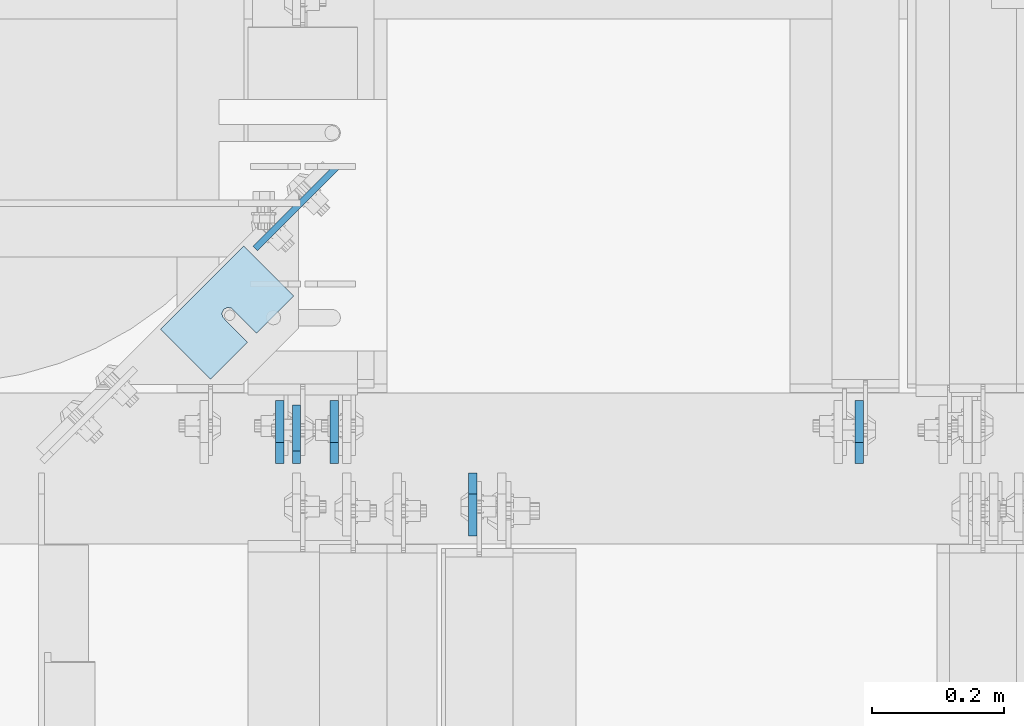
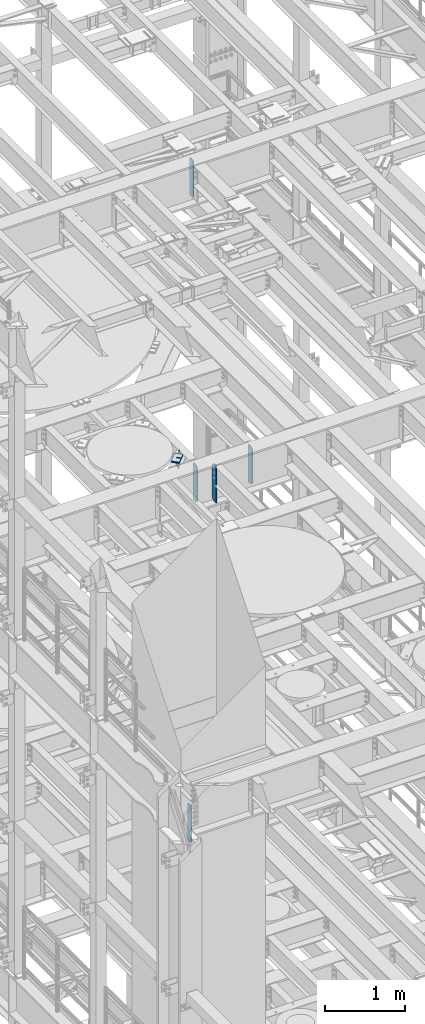
# One storey, part 1719 of 1876: 11 plates, 9 elements without a shape of their own.
"""IFC2X3 building model written with IfcOpenShell, lengths in millimetres."""

from ifc_helpers import new_model, si_unit, frame, origin_with_axes, place, context, subcontext, project, spatial, faceted_brep, material, type_object, element, aggregate, save


model = new_model("IFC2X3")

# Units and contexts
model_context = context("Model", 3, precision=1e-05, world=origin_with_axes())
body_context = subcontext(model_context, "Body", "Model", "MODEL_VIEW")
ifc_project = project(units=[si_unit("LENGTHUNIT", "METRE", prefix="MILLI"), si_unit("AREAUNIT", "SQUARE_METRE"), si_unit("VOLUMEUNIT", "CUBIC_METRE"), si_unit("MASSUNIT", "GRAM", prefix="KILO"), si_unit("TIMEUNIT", "SECOND"), si_unit("PLANEANGLEUNIT", "RADIAN"), si_unit("SOLIDANGLEUNIT", "STERADIAN"), si_unit("THERMODYNAMICTEMPERATUREUNIT", "DEGREE_CELSIUS"), si_unit("LUMINOUSINTENSITYUNIT", "LUMEN")], contexts=[model_context])

# Site, building, storey
site_placement = place(None, origin_with_axes())
site = spatial("IfcSite", under=ifc_project, at=site_placement, CompositionType="ELEMENT")
building_placement = place(site_placement, origin_with_axes())
building = spatial("IfcBuilding", under=site, at=building_placement, Name="Undefined", CompositionType="ELEMENT")
storey_placement = place(building_placement, origin_with_axes())
storey = spatial("IfcBuildingStorey", under=building, at=storey_placement, Name="Undefined", CompositionType="ELEMENT", Elevation=0.0)

# Assembly, plate
assembly_1_placement = place(storey_placement, origin_with_axes())
assembly_1 = element("IfcElementAssembly", 1, at=assembly_1_placement, inside=storey, Name="BEAM", AssemblyPlace="NOTDEFINED", PredefinedType="RIGID_FRAME")
ifc_material = material(Name="STEEL/A36")
plate_type_1 = type_object("IfcPlateType", PredefinedType="NOTDEFINED")
plate_1_placement = place(assembly_1_placement, frame((3784.40740341513, 8075.21362106345, 13275.2197438789), z_axis=(-0.707106781186547, -0.707106781186548, 0.0), x_axis=(0.0, 0.0, -1.0)))
plate_1 = element("IfcPlate", 2, at=plate_1_placement, type_object=plate_type_1, material=ifc_material, Name="PLATE", context=body_context, shape_type="Brep", body=[
    faceted_brep([(0.0, -4.76249999999982, 0.0), (0.0, -4.76250000000073, 173.535507202178), (0.0, 4.76250000000073, 173.535507202178), (0.0, 4.76249999999982, 0.0), (245.070301055908, -4.76250000000073, 1.81898940354586e-12), (245.070301055908, 4.76250000000255, 9.09494701772928e-13), (264.120300292969, -4.76249999999891, 19.0499992370651), (264.120300292969, 4.76250000000073, 19.0499992370651), (264.120300292969, -4.76250000000073, 63.5000000707769), (118.019743991599, -4.76250000000073, 173.535507202179), (118.019743991599, 4.76250000000073, 173.53550720218), (264.120300292969, 4.76250000000073, 63.5000000707773)], [[[0, 1, 2, 3]], [[4, 0, 3, 5]], [[6, 4, 5, 7]], [[1, 0, 4, 6, 8, 9]], [[2, 1, 9, 10]], [[7, 5, 3, 2, 10, 11]], [[6, 7, 11, 8]], [[10, 9, 8, 11]]]),
])
aggregate(assembly_1, [plate_1])

assembly_2_placement = place(storey_placement, origin_with_axes())
assembly_2 = element("IfcElementAssembly", 3, at=assembly_2_placement, inside=storey, Name="BEAM", AssemblyPlace="NOTDEFINED", PredefinedType="RIGID_FRAME")
plate_type_2 = type_object("IfcPlateType", PredefinedType="NOTDEFINED")
plate_2_placement = place(assembly_2_placement, frame((3724.27530593044, 7627.14375, 17387.8875), z_axis=(0.0, 0.0, 1.0), x_axis=(0.0, 1.0, 0.0)))
plate_2 = element("IfcPlate", 4, at=plate_2_placement, type_object=plate_type_2, material=ifc_material, Name="PLATE", context=body_context, shape_type="Brep", body=[
    faceted_brep([(0.0, -6.35000000000196, 19.0499992370605), (0.0, -6.34999999999991, 550.862476348877), (0.0, 6.34999999999991, 550.862476348877), (0.0, 6.35000000000105, 19.0499992370605), (19.0499992370605, -6.34999999999991, 569.912475585938), (19.0499992370605, 6.34999999999991, 569.912475585938), (88.9000015258616, -6.35000000001173, 569.912475585938), (88.9000015258634, 6.34999999998627, 569.912475585938), (88.9000015258789, -6.34999999999991, 0.0), (88.9000015258789, 6.34999999999991, 0.0), (19.0499992370642, -6.35000000000105, 0.0), (19.0499992370633, 6.35000000000105, 0.0)], [[[0, 1, 2, 3]], [[1, 4, 5, 2]], [[4, 6, 7, 5]], [[6, 8, 9, 7]], [[8, 10, 11, 9]], [[10, 0, 3, 11]], [[5, 7, 9, 11, 3, 2]], [[10, 8, 6, 4, 1, 0]]]),
])
aggregate(assembly_2, [plate_2])

assembly_3_placement = place(storey_placement, origin_with_axes())
assembly_3 = element("IfcElementAssembly", 5, at=assembly_3_placement, inside=storey, Name="BEAM", AssemblyPlace="NOTDEFINED", PredefinedType="RIGID_FRAME")
plate_type_3 = type_object("IfcPlateType", PredefinedType="NOTDEFINED")
plate_3_placement = place(assembly_3_placement, frame((3698.87499990463, 7627.14375, 7558.0875), z_axis=(0.0, 0.0, 1.0), x_axis=(0.0, 1.0, 0.0)))
plate_3 = element("IfcPlate", 6, at=plate_3_placement, type_object=plate_type_3, material=ifc_material, Name="PLATE", context=body_context, shape_type="Brep", body=[
    faceted_brep([(0.0, -6.34999999999991, 31.75), (0.0, -6.35000000000036, 538.162475585938), (0.0, 6.35000000000036, 538.162475585938), (0.0, 6.34999999999991, 31.75), (31.75, -6.35000000000036, 569.912475585938), (31.75, 6.35000000000036, 569.912475585938), (95.25, -6.35000000000036, 569.912475585938), (95.25, 6.35000000000036, 569.912475585938), (95.25, -6.35000000000036, 0.0), (95.25, 6.35000000000036, 0.0), (31.75, -6.34999999999991, 0.0), (31.75, 6.34999999999991, 0.0)], [[[0, 1, 2, 3]], [[1, 4, 5, 2]], [[4, 6, 7, 5]], [[6, 8, 9, 7]], [[8, 10, 11, 9]], [[10, 0, 3, 11]], [[5, 7, 9, 11, 3, 2]], [[10, 8, 6, 4, 1, 0]]]),
])
aggregate(assembly_3, [plate_3])

# Assembly, plates
assembly_4_placement = place(storey_placement, origin_with_axes())
assembly_4 = element("IfcElementAssembly", 7, at=assembly_4_placement, inside=storey, Name="BEAM", AssemblyPlace="NOTDEFINED", PredefinedType="RIGID_FRAME")
plate_4_placement = place(assembly_4_placement, frame((4575.17499990465, 7627.14375, 12714.2875), z_axis=(0.0, 0.0, 1.0), x_axis=(0.0, 1.0, 0.0)))
plate_4 = element("IfcPlate", 8, at=plate_4_placement, type_object=plate_type_3, material=ifc_material, Name="PLATE", context=body_context, shape_type="Brep", body=[
    faceted_brep([(0.0, -6.34999999999991, 31.75), (0.0, -6.35000000000036, 538.162475585938), (0.0, 6.35000000000036, 538.162475585938), (0.0, 6.34999999999991, 31.75), (31.75, -6.35000000000036, 569.912475585938), (31.75, 6.35000000000036, 569.912475585938), (95.25, -6.35000000000036, 569.912475585938), (95.25, 6.35000000000036, 569.912475585938), (95.25, -6.35000000000036, 0.0), (95.25, 6.35000000000036, 0.0), (31.75, -6.34999999999991, 0.0), (31.75, 6.34999999999991, 0.0)], [[[0, 1, 2, 3]], [[1, 4, 5, 2]], [[4, 6, 7, 5]], [[6, 8, 9, 7]], [[8, 10, 11, 9]], [[10, 0, 3, 11]], [[5, 7, 9, 11, 3, 2]], [[10, 8, 6, 4, 1, 0]]]),
])
plate_5_placement = place(assembly_4_placement, frame((3781.42499990463, 7627.14375, 12714.2875), z_axis=(0.0, 0.0, 1.0), x_axis=(0.0, 1.0, 0.0)))
plate_5 = element("IfcPlate", 9, at=plate_5_placement, type_object=plate_type_3, material=ifc_material, Name="PLATE", context=body_context, shape_type="Brep", body=[
    faceted_brep([(0.0, -6.34999999999991, 31.75), (0.0, -6.35000000000036, 538.162475585938), (0.0, 6.35000000000036, 538.162475585938), (0.0, 6.34999999999991, 31.75), (31.75, -6.35000000000036, 569.912475585938), (31.75, 6.35000000000036, 569.912475585938), (95.25, -6.35000000000036, 569.912475585938), (95.25, 6.35000000000036, 569.912475585938), (95.25, -6.35000000000036, 0.0), (95.25, 6.35000000000036, 0.0), (31.75, -6.34999999999991, 0.0), (31.75, 6.34999999999991, 0.0)], [[[0, 1, 2, 3]], [[1, 4, 5, 2]], [[4, 6, 7, 5]], [[6, 8, 9, 7]], [[8, 10, 11, 9]], [[10, 0, 3, 11]], [[5, 7, 9, 11, 3, 2]], [[10, 8, 6, 4, 1, 0]]]),
])
plate_6_placement = place(assembly_4_placement, frame((3990.97499990463, 7612.85625, 12714.2875), z_axis=(0.0, 0.0, 1.0), x_axis=(0.0, -1.0, 0.0)))
plate_6 = element("IfcPlate", 10, at=plate_6_placement, type_object=plate_type_3, material=ifc_material, Name="PLATE", context=body_context, shape_type="Brep", body=[
    faceted_brep([(0.0, -6.34999999999991, 31.75), (0.0, -6.35000000000036, 538.162475585938), (0.0, 6.35000000000036, 538.162475585938), (0.0, 6.34999999999991, 31.75), (31.75, -6.35000000000036, 569.912475585938), (31.75, 6.35000000000036, 569.912475585938), (95.25, -6.35000000000036, 569.912475585938), (95.25, 6.35000000000036, 569.912475585938), (95.25, -6.35000000000036, 0.0), (95.25, 6.35000000000036, 0.0), (31.75, -6.34999999999991, 0.0), (31.75, 6.34999999999991, 0.0)], [[[0, 1, 2, 3]], [[1, 4, 5, 2]], [[4, 6, 7, 5]], [[6, 8, 9, 7]], [[8, 10, 11, 9]], [[10, 0, 3, 11]], [[5, 7, 9, 11, 3, 2]], [[10, 8, 6, 4, 1, 0]]]),
])
aggregate(assembly_4, [plate_4, plate_5, plate_6])

# Assembly, plate
assembly_5_placement = place(storey_placement, origin_with_axes())
assembly_5 = element("IfcElementAssembly", 11, at=assembly_5_placement, inside=storey, Name="SHIM PLATE", AssemblyPlace="NOTDEFINED", PredefinedType="RIGID_FRAME")
plate_type_4 = type_object("IfcPlateType", PredefinedType="NOTDEFINED")
plate_7_placement = place(assembly_5_placement, frame((3518.69760703957, 7830.37621876371, 13333.4115), z_axis=(0.707118099095974, 0.707095463095965, 0.0), x_axis=(0.707095463095965, -0.707118099095973, 0.0)))
plate_7 = element("IfcPlate", 12, at=plate_7_placement, type_object=plate_type_4, material=ifc_material, Name="SHIM PLATE", context=body_context, shape_type="Brep", body=[
    faceted_brep([(106.568541254128, -1.58749999999964, 79.3765579294436), (106.568541254128, 1.58749999999964, 79.3765579294436), (58.9506147729862, 1.58749999999964, 79.3744311916935), (58.9506147729862, -1.58749999999964, 79.3744311916935), (52.9160762669235, 1.58749999999964, 79.5269726944384), (52.9160762669235, -1.58749999999964, 79.5269726944384), (48.0867887969489, 1.58749999999964, 83.1486996890617), (48.0867887969489, -1.58749999999964, 83.1486996890617), (46.2503144929269, 1.58749999999964, 88.8990288989303), (46.2503144929269, -1.58749999999964, 88.8990288989303), (48.0864248405524, 1.58749999999964, 94.6494743323319), (48.0864248405524, -1.58749999999964, 94.6494743323319), (52.9154830726966, 1.58749999999964, 98.2715069773753), (52.9154830726966, -1.58749999999964, 98.2715069773753), (58.9500119119384, 1.58749999999964, 98.4244304208414), (58.9500119119384, -1.58749999999964, 98.4244304208414), (106.568229878943, -1.58749999999964, 98.4265571589231), (106.568520818602, 1.58749999999964, 98.426557159235), (106.568626403816, -1.58749999999964, 1.04591890703887e-11), (9.09494701772928e-13, -1.58750000000146, 4.54747350886464e-13), (9.09494701772928e-13, 1.58750000000146, 4.54747350886464e-13), (106.568626403816, 1.58749999999964, 1.04591890703887e-11), (-0.0860888362312835, -1.58749999999964, 177.799743652413), (-0.0860888362312835, 1.58749999999964, 177.799743652413), (106.568435668914, -1.58749999999964, 177.803115844784), (106.568435668914, 1.58749999999964, 177.803115844784)], [[[0, 1, 2, 3]], [[3, 2, 4, 5]], [[5, 4, 6, 7]], [[7, 6, 8, 9]], [[9, 8, 10, 11]], [[11, 10, 12, 13]], [[13, 12, 14, 15]], [[16, 15, 14, 17]], [[18, 19, 20, 21]], [[19, 22, 23, 20]], [[22, 24, 25, 23]], [[25, 24, 16, 17]], [[12, 10, 8, 6, 4, 2, 1, 21, 20, 23, 25, 17, 14]], [[18, 21, 1, 0]], [[24, 22, 19, 18, 0, 3, 5, 7, 9, 11, 13, 15, 16]]]),
])
aggregate(assembly_5, [plate_7])

assembly_6_placement = place(storey_placement, origin_with_axes())
assembly_6 = element("IfcElementAssembly", 13, at=assembly_6_placement, inside=storey, Name="SHIM PLATE", AssemblyPlace="NOTDEFINED", PredefinedType="RIGID_FRAME")
plate_8_placement = place(assembly_6_placement, frame((3518.69760703957, 7830.37621876371, 13330.2365), z_axis=(0.707118099095974, 0.707095463095965, 0.0), x_axis=(0.707095463095965, -0.707118099095973, 0.0)))
plate_8 = element("IfcPlate", 14, at=plate_8_placement, type_object=plate_type_4, material=ifc_material, Name="SHIM PLATE", context=body_context, shape_type="Brep", body=[
    faceted_brep([(106.568541254128, -1.58749999999964, 79.3765579294436), (106.568541254128, 1.58749999999964, 79.3765579294436), (58.9506147729862, 1.58749999999964, 79.3744311916935), (58.9506147729862, -1.58749999999964, 79.3744311916935), (52.9160762669235, 1.58749999999964, 79.5269726944384), (52.9160762669235, -1.58749999999964, 79.5269726944384), (48.0867887969489, 1.58749999999964, 83.1486996890617), (48.0867887969489, -1.58749999999964, 83.1486996890617), (46.2503144929269, 1.58749999999964, 88.8990288989303), (46.2503144929269, -1.58749999999964, 88.8990288989303), (48.0864248405524, 1.58749999999964, 94.6494743323319), (48.0864248405524, -1.58749999999964, 94.6494743323319), (52.9154830726966, 1.58749999999964, 98.2715069773753), (52.9154830726966, -1.58749999999964, 98.2715069773753), (58.9500119119384, 1.58749999999964, 98.4244304208414), (58.9500119119384, -1.58749999999964, 98.4244304208414), (106.568229878943, -1.58749999999964, 98.4265571589231), (106.568520818602, 1.58749999999964, 98.426557159235), (106.568626403816, -1.58749999999964, 1.04591890703887e-11), (9.09494701772928e-13, -1.58750000000146, 4.54747350886464e-13), (9.09494701772928e-13, 1.58750000000146, 4.54747350886464e-13), (106.568626403816, 1.58749999999964, 1.04591890703887e-11), (-0.0860888362312835, -1.58749999999964, 177.799743652413), (-0.0860888362312835, 1.58749999999964, 177.799743652413), (106.568435668914, -1.58749999999964, 177.803115844784), (106.568435668914, 1.58749999999964, 177.803115844784)], [[[0, 1, 2, 3]], [[3, 2, 4, 5]], [[5, 4, 6, 7]], [[7, 6, 8, 9]], [[9, 8, 10, 11]], [[11, 10, 12, 13]], [[13, 12, 14, 15]], [[16, 15, 14, 17]], [[18, 19, 20, 21]], [[19, 22, 23, 20]], [[22, 24, 25, 23]], [[25, 24, 16, 17]], [[12, 10, 8, 6, 4, 2, 1, 21, 20, 23, 25, 17, 14]], [[18, 21, 1, 0]], [[24, 22, 19, 18, 0, 3, 5, 7, 9, 11, 13, 15, 16]]]),
])
aggregate(assembly_6, [plate_8])

assembly_7_placement = place(storey_placement, origin_with_axes())
assembly_7 = element("IfcElementAssembly", 15, at=assembly_7_placement, inside=storey, Name="SHIM PLATE", AssemblyPlace="NOTDEFINED", PredefinedType="RIGID_FRAME")
plate_type_5 = type_object("IfcPlateType", PredefinedType="NOTDEFINED")
plate_9_placement = place(assembly_7_placement, frame((3518.69760703957, 7830.37621876371, 13326.268), z_axis=(0.707118099095974, 0.707095463095965, 0.0), x_axis=(0.707095463095965, -0.707118099095973, 0.0)))
plate_9 = element("IfcPlate", 16, at=plate_9_placement, type_object=plate_type_5, material=ifc_material, Name="SHIM PLATE", context=body_context, shape_type="Brep", body=[
    faceted_brep([(106.568541254128, -2.3809999999994, 79.3765579294427), (106.568541254128, 2.3809999999994, 79.3765579294427), (58.950614772988, 2.3809999999994, 79.374431191693), (58.950614772988, -2.3809999999994, 79.374431191693), (52.9160762669253, 2.3809999999994, 79.5269726944375), (52.9160762669253, -2.3809999999994, 79.5269726944375), (48.0867887969507, 2.3809999999994, 83.1486996890608), (48.0867887969507, -2.3809999999994, 83.1486996890608), (46.2503144929269, 2.3809999999994, 88.8990288989298), (46.2503144929269, -2.3809999999994, 88.8990288989298), (48.0864248405542, 2.3809999999994, 94.6494743323319), (48.0864248405542, -2.3809999999994, 94.6494743323319), (52.9154830726984, 2.3809999999994, 98.2715069773753), (52.9154830726984, -2.3809999999994, 98.2715069773753), (58.9500119119384, 2.3809999999994, 98.4244304208405), (58.9500119119384, -2.3809999999994, 98.4244304208405), (106.568229878945, -2.3809999999994, 98.4265571589222), (106.568520818604, 2.3809999999994, 98.4265571592341), (106.568626403816, -2.3809999999994, -2.50111042987555e-11), (0.0, -2.38100000000122, 4.54747350886464e-13), (0.0, 2.38100000000122, 4.54747350886464e-13), (106.568626403816, 2.3809999999994, -2.50111042987555e-11), (-0.0860888362312835, -2.3809999999994, 177.799743652412), (-0.0860888362312835, 2.3809999999994, 177.799743652412), (106.568435668916, -2.3809999999994, 177.803115844784), (106.568435668916, 2.3809999999994, 177.803115844784)], [[[0, 1, 2, 3]], [[3, 2, 4, 5]], [[5, 4, 6, 7]], [[7, 6, 8, 9]], [[9, 8, 10, 11]], [[11, 10, 12, 13]], [[13, 12, 14, 15]], [[16, 15, 14, 17]], [[18, 19, 20, 21]], [[19, 22, 23, 20]], [[22, 24, 25, 23]], [[25, 24, 16, 17]], [[12, 10, 8, 6, 4, 2, 1, 21, 20, 23, 25, 17, 14]], [[18, 21, 1, 0]], [[24, 22, 19, 18, 0, 3, 5, 7, 9, 11, 13, 15, 16]]]),
])
aggregate(assembly_7, [plate_9])

assembly_8_placement = place(storey_placement, origin_with_axes())
assembly_8 = element("IfcElementAssembly", 17, at=assembly_8_placement, inside=storey, Name="SHIM PLATE", AssemblyPlace="NOTDEFINED", PredefinedType="RIGID_FRAME")
plate_10_placement = place(assembly_8_placement, frame((3518.69760703957, 7830.37621876371, 13321.506), z_axis=(0.707118099095974, 0.707095463095965, 0.0), x_axis=(0.707095463095965, -0.707118099095973, 0.0)))
plate_10 = element("IfcPlate", 18, at=plate_10_placement, type_object=plate_type_5, material=ifc_material, Name="SHIM PLATE", context=body_context, shape_type="Brep", body=[
    faceted_brep([(106.568541254128, -2.3809999999994, 79.3765579294427), (106.568541254128, 2.3809999999994, 79.3765579294427), (58.950614772988, 2.3809999999994, 79.374431191693), (58.950614772988, -2.3809999999994, 79.374431191693), (52.9160762669253, 2.3809999999994, 79.5269726944375), (52.9160762669253, -2.3809999999994, 79.5269726944375), (48.0867887969507, 2.3809999999994, 83.1486996890608), (48.0867887969507, -2.3809999999994, 83.1486996890608), (46.2503144929269, 2.3809999999994, 88.8990288989298), (46.2503144929269, -2.3809999999994, 88.8990288989298), (48.0864248405542, 2.3809999999994, 94.6494743323319), (48.0864248405542, -2.3809999999994, 94.6494743323319), (52.9154830726984, 2.3809999999994, 98.2715069773753), (52.9154830726984, -2.3809999999994, 98.2715069773753), (58.9500119119384, 2.3809999999994, 98.4244304208405), (58.9500119119384, -2.3809999999994, 98.4244304208405), (106.568229878945, -2.3809999999994, 98.4265571589222), (106.568520818604, 2.3809999999994, 98.4265571592341), (106.568626403816, -2.3809999999994, -2.50111042987555e-11), (0.0, -2.38100000000122, 4.54747350886464e-13), (0.0, 2.38100000000122, 4.54747350886464e-13), (106.568626403816, 2.3809999999994, -2.50111042987555e-11), (-0.0860888362312835, -2.3809999999994, 177.799743652412), (-0.0860888362312835, 2.3809999999994, 177.799743652412), (106.568435668916, -2.3809999999994, 177.803115844784), (106.568435668916, 2.3809999999994, 177.803115844784)], [[[0, 1, 2, 3]], [[3, 2, 4, 5]], [[5, 4, 6, 7]], [[7, 6, 8, 9]], [[9, 8, 10, 11]], [[11, 10, 12, 13]], [[13, 12, 14, 15]], [[16, 15, 14, 17]], [[18, 19, 20, 21]], [[19, 22, 23, 20]], [[22, 24, 25, 23]], [[25, 24, 16, 17]], [[12, 10, 8, 6, 4, 2, 1, 21, 20, 23, 25, 17, 14]], [[18, 21, 1, 0]], [[24, 22, 19, 18, 0, 3, 5, 7, 9, 11, 13, 15, 16]]]),
])
aggregate(assembly_8, [plate_10])

assembly_9_placement = place(storey_placement, origin_with_axes())
assembly_9 = element("IfcElementAssembly", 19, at=assembly_9_placement, inside=storey, Name="SHIM PLATE", AssemblyPlace="NOTDEFINED", PredefinedType="RIGID_FRAME")
plate_type_6 = type_object("IfcPlateType", PredefinedType="NOTDEFINED")
plate_11_placement = place(assembly_9_placement, frame((3518.69760703957, 7830.37621876371, 13314.3625), z_axis=(0.707118099095974, 0.707095463095965, 0.0), x_axis=(0.707095463095965, -0.707118099095973, 0.0)))
plate_11 = element("IfcPlate", 20, at=plate_11_placement, type_object=plate_type_6, material=ifc_material, Name="SHIM PLATE", context=body_context, shape_type="Brep", body=[
    faceted_brep([(106.568541254128, -4.76250000000073, 79.3765579294432), (106.568541254128, 4.76250000000073, 79.3765579294432), (58.950614772988, 4.76250000000073, 79.3744311916935), (58.950614772988, -4.76250000000073, 79.3744311916935), (52.9160762669235, 4.76250000000073, 79.5269726944393), (52.9160762669235, -4.76250000000073, 79.5269726944393), (48.0867887969489, 4.76250000000073, 83.1486996890617), (48.0867887969489, -4.76250000000073, 83.1486996890617), (46.2503144929269, 4.76250000000073, 88.8990288989303), (46.2503144929269, -4.76250000000073, 88.8990288989303), (48.0864248405524, 4.76250000000073, 94.6494743323324), (48.0864248405524, -4.76250000000073, 94.6494743323324), (52.9154830726966, 4.76250000000073, 98.2715069773762), (52.9154830726966, -4.76250000000073, 98.2715069773762), (58.9500119119384, 4.76250000000073, 98.4244304208414), (58.9500119119384, -4.76250000000073, 98.4244304208414), (106.568229878945, -4.76250000000073, 98.4265571589226), (106.568520818604, 4.76250000000073, 98.426557159235), (106.568626403816, -4.76250000000073, 9.54969436861575e-12), (0.0, -4.76249999999982, 0.0), (0.0, 4.76249999999982, 0.0), (106.568626403816, 4.76250000000073, 9.54969436861575e-12), (-0.0860888362312835, -4.76250000000073, 177.799743652414), (-0.0860888362312835, 4.76250000000073, 177.799743652414), (106.568435668916, -4.76250000000073, 177.803115844784), (106.568435668916, 4.76250000000073, 177.803115844784)], [[[0, 1, 2, 3]], [[3, 2, 4, 5]], [[5, 4, 6, 7]], [[7, 6, 8, 9]], [[9, 8, 10, 11]], [[11, 10, 12, 13]], [[13, 12, 14, 15]], [[16, 15, 14, 17]], [[18, 19, 20, 21]], [[19, 22, 23, 20]], [[22, 24, 25, 23]], [[25, 24, 16, 17]], [[12, 10, 8, 6, 4, 2, 1, 21, 20, 23, 25, 17, 14]], [[18, 21, 1, 0]], [[24, 22, 19, 18, 0, 3, 5, 7, 9, 11, 13, 15, 16]]]),
])
aggregate(assembly_9, [plate_11])

save(model, "model.ifc")
